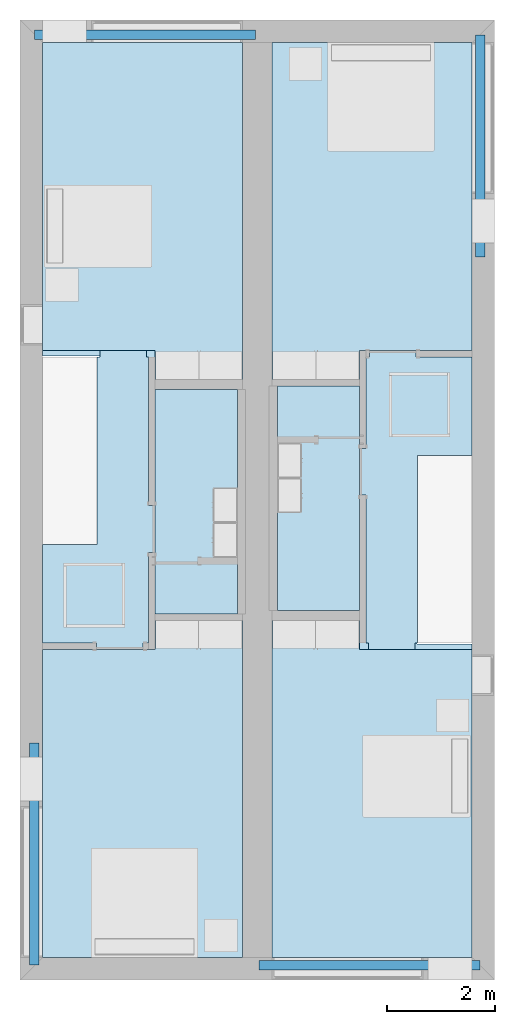
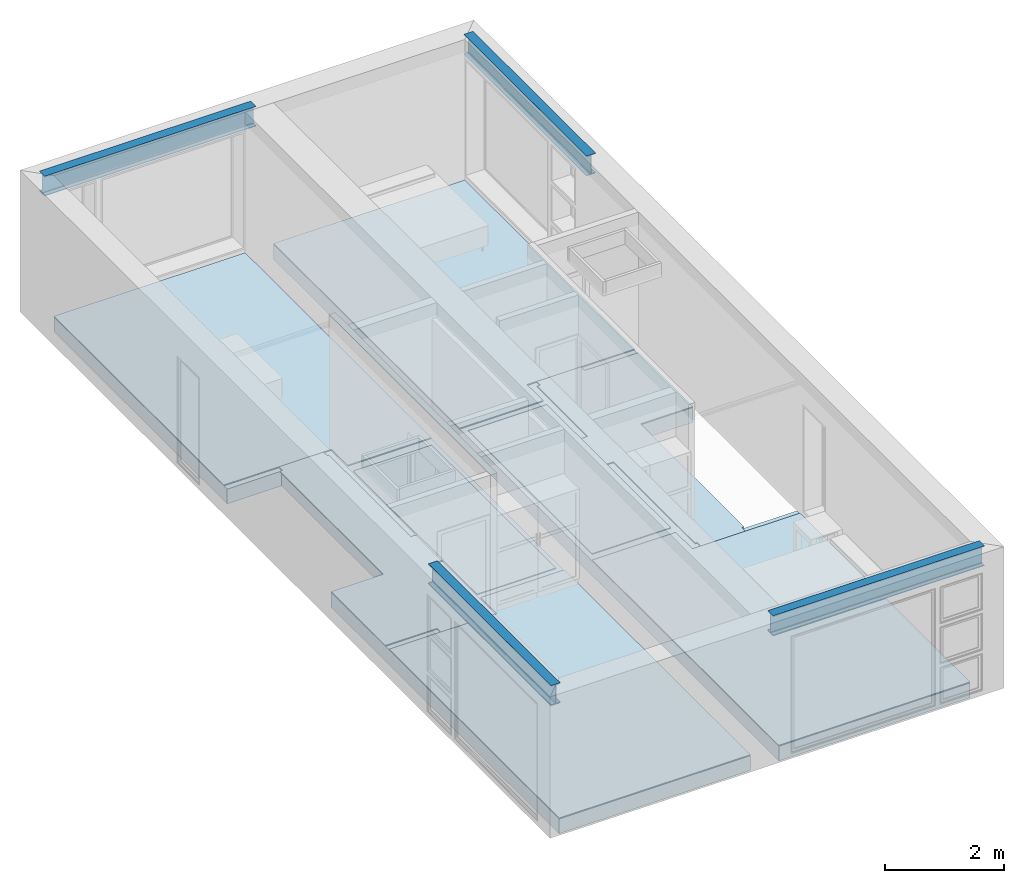
# One storey, part 1 of 12: 10 slabs, 4 beams.
"""IFC2X3 building model written with IfcOpenShell, lengths in metres."""

from ifc_helpers import new_model, entity, si_unit, converted_unit, frame, frame_2d, origin, place, context, project, spatial, polyline, circle_curve, parameter, trimmed, segment, composite_curve, rectangle, outline, extrude, material, layer, layer_set, layer_usage, element, save


model = new_model("IFC2X3")

# Units and contexts
model_context = context("Model", 3, precision=1e-09, world=origin())
plan_context = context("Plan", 3, precision=1e-09, world=origin())
ifc_project = project(units=[si_unit("LENGTHUNIT", "METRE"), si_unit("AREAUNIT", "SQUARE_METRE"), si_unit("VOLUMEUNIT", "CUBIC_METRE"), converted_unit("PLANEANGLEUNIT", "DEGREE", entity("IfcRatioMeasure", 0.0174532925199433), si_unit("PLANEANGLEUNIT", "RADIAN"), dimensions=[0, 0, 0, 0, 0, 0, 0]), si_unit("TIMEUNIT", "SECOND")], contexts=[model_context, plan_context])

# Site, building, storey
site_placement = place(None, origin())
site = spatial("IfcSite", under=ifc_project, at=site_placement, CompositionType="ELEMENT")
building_placement = place(site_placement, origin())
building = spatial("IfcBuilding", under=site, at=building_placement, CompositionType="ELEMENT")
storey_placement = place(building_placement, frame((0.0, 0.0, 3.10000000000038)))
storey = spatial("IfcBuildingStorey", under=building, at=storey_placement, Name="Level 2", CompositionType="ELEMENT", Elevation=3.10000000000038)

# Beams
ifc_material_1 = material(Name="Metal - Steel - 345 MPa")
beam_1_placement = place(storey_placement, frame((0.266612879575049, -13.4017200713696, 2.89999999999983), z_axis=(0.0, 0.0, 1.0), x_axis=(-1.0, 0.0, 0.0)))
element("IfcBeam", 1, at=beam_1_placement, inside=storey, material=ifc_material_1, context=model_context, shape_type="SweptSolid", body=[
    extrude(outline(composite_curve([segment(polyline([(0.190699999999998, -0.0890000000000002), (0.203499999999999, -0.0890000000000002)]), True, "CONTINUOUS"), segment(polyline([(0.203499999999999, -0.0890000000000002), (0.203499999999999, 0.089)]), True, "CONTINUOUS"), segment(polyline([(0.203499999999999, 0.089), (0.190699999999998, 0.089)]), True, "CONTINUOUS"), segment(polyline([(0.190699999999998, 0.089), (0.190699999999998, 0.02105)]), True, "CONTINUOUS"), segment(trimmed(circle_curve(frame_2d((0.173499999999998, 0.0210499999999999), x_axis=(1.0, 0.0)), 0.0172), [parameter(270.0)], [parameter(360.0)], True, "PARAMETER"), False, "CONTINUOUS"), segment(polyline([(0.173499999999998, 0.00384999999999994), (-0.173500000000002, 0.00384999999999994)]), True, "CONTINUOUS"), segment(trimmed(circle_curve(frame_2d((-0.173500000000002, 0.0210499999999999), x_axis=(0.0, -1.0)), 0.0172), [parameter(270.0)], [parameter(360.0)], True, "PARAMETER"), False, "CONTINUOUS"), segment(polyline([(-0.190700000000002, 0.02105), (-0.190700000000002, 0.089)]), True, "CONTINUOUS"), segment(polyline([(-0.190700000000002, 0.089), (-0.203500000000001, 0.089)]), True, "CONTINUOUS"), segment(polyline([(-0.203500000000001, 0.0890000000000001), (-0.203500000000001, -0.0889999999999996)]), True, "CONTINUOUS"), segment(polyline([(-0.203500000000001, -0.0889999999999996), (-0.190700000000002, -0.0889999999999996)]), True, "CONTINUOUS"), segment(polyline([(-0.190700000000002, -0.0889999999999996), (-0.190700000000002, -0.0210500000000001)]), True, "CONTINUOUS"), segment(trimmed(circle_curve(frame_2d((-0.173500000000002, -0.0210500000000002), x_axis=(-1.0, 0.0)), 0.0172), [parameter(270.0)], [parameter(0.0)], True, "PARAMETER"), False, "CONTINUOUS"), segment(polyline([(-0.173500000000002, -0.00385000000000014), (0.173499999999998, -0.00385000000000014)]), True, "CONTINUOUS"), segment(trimmed(circle_curve(frame_2d((0.173499999999998, -0.0210500000000002), x_axis=(0.0, 1.0)), 0.0172), [parameter(270.0)], [parameter(5.08888749034163e-14)], True, "PARAMETER"), False, "CONTINUOUS"), segment(polyline([(0.190699999999998, -0.0210500000000001), (0.190699999999998, -0.0890000000000002)]), True, "CONTINUOUS")], self_intersect=False)), frame((0.0, 4.12127992863035, -0.203500000000007), z_axis=(0.0, -1.0, 0.0), x_axis=(0.0, 0.0, -1.0)), (0.0, 0.0, 1.0), 4.12127992863035),
])
beam_2_placement = place(storey_placement, frame((4.42895432874427, -17.5287668629737, 2.89999999999983), z_axis=(0.0, 0.0, 1.0), x_axis=(0.0, -1.0, 0.0)))
element("IfcBeam", 2, at=beam_2_placement, inside=storey, material=ifc_material_1, context=model_context, shape_type="SweptSolid", body=[
    extrude(outline(composite_curve([segment(polyline([(-0.0890000000000036, -0.1907), (-0.0890000000000036, -0.203500000000001)]), True, "CONTINUOUS"), segment(polyline([(-0.0890000000000036, -0.203500000000001), (0.0889999999999971, -0.203500000000001)]), True, "CONTINUOUS"), segment(polyline([(0.0889999999999971, -0.203500000000001), (0.0889999999999971, -0.1907)]), True, "CONTINUOUS"), segment(polyline([(0.0889999999999971, -0.1907), (0.0210499999999974, -0.1907)]), True, "CONTINUOUS"), segment(trimmed(circle_curve(frame_2d((0.0210499999999974, -0.173500000000001), x_axis=(0.0, -1.0)), 0.0172), [parameter(270.0)], [parameter(360.0)], True, "PARAMETER"), False, "CONTINUOUS"), segment(polyline([(0.00384999999999696, -0.173500000000001), (0.00384999999999696, 0.173499999999999)]), True, "CONTINUOUS"), segment(trimmed(circle_curve(frame_2d((0.0210499999999974, 0.173499999999999), x_axis=(-1.0, 0.0)), 0.0172), [parameter(270.0)], [parameter(360.0)], True, "PARAMETER"), False, "CONTINUOUS"), segment(polyline([(0.0210499999999952, 0.1907), (0.0889999999999971, 0.1907)]), True, "CONTINUOUS"), segment(polyline([(0.0889999999999971, 0.1907), (0.0889999999999971, 0.203499999999999)]), True, "CONTINUOUS"), segment(polyline([(0.0889999999999971, 0.203499999999999), (-0.0890000000000036, 0.203499999999999)]), True, "CONTINUOUS"), segment(polyline([(-0.0890000000000036, 0.203499999999999), (-0.0890000000000036, 0.1907)]), True, "CONTINUOUS"), segment(polyline([(-0.0890000000000036, 0.1907), (-0.0210500000000039, 0.1907)]), True, "CONTINUOUS"), segment(trimmed(circle_curve(frame_2d((-0.0210500000000039, 0.173499999999999), x_axis=(0.0, 1.0)), 0.0172), [parameter(270.0)], [parameter(0.0)], True, "PARAMETER"), False, "CONTINUOUS"), segment(polyline([(-0.00385000000000346, 0.173499999999999), (-0.00385000000000346, -0.173500000000001)]), True, "CONTINUOUS"), segment(trimmed(circle_curve(frame_2d((-0.0210500000000039, -0.173500000000001), x_axis=(1.0, 0.0)), 0.0172), [parameter(270.0)], [parameter(5.08888749034163e-14)], True, "PARAMETER"), False, "CONTINUOUS"), segment(polyline([(-0.0210500000000039, -0.1907), (-0.0890000000000036, -0.1907)]), True, "CONTINUOUS")], self_intersect=False)), frame((0.0, 0.0, -0.203500000000005), z_axis=(0.0, -1.0, 0.0), x_axis=(1.0, 0.0, 0.0)), (0.0, 0.0, -1.0), 4.1),
])
beam_3_placement = place(storey_placement, frame((8.53338712042497, -4.39827992863039, 2.89999999999983)))
element("IfcBeam", 3, at=beam_3_placement, inside=storey, material=ifc_material_1, context=model_context, shape_type="SweptSolid", body=[
    extrude(outline(composite_curve([segment(polyline([(-0.0890000000000003, -0.1907), (-0.0890000000000003, -0.203500000000001)]), True, "CONTINUOUS"), segment(polyline([(-0.0890000000000003, -0.203500000000001), (0.0889999999999993, -0.203500000000001)]), True, "CONTINUOUS"), segment(polyline([(0.0889999999999993, -0.203500000000001), (0.0889999999999993, -0.1907)]), True, "CONTINUOUS"), segment(polyline([(0.0889999999999993, -0.1907), (0.0210499999999996, -0.1907)]), True, "CONTINUOUS"), segment(trimmed(circle_curve(frame_2d((0.0210499999999996, -0.173500000000001), x_axis=(0.0, -1.0)), 0.0172), [parameter(270.0)], [parameter(360.0)], True, "PARAMETER"), False, "CONTINUOUS"), segment(polyline([(0.00384999999999912, -0.173500000000001), (0.00384999999999912, 0.173499999999999)]), True, "CONTINUOUS"), segment(trimmed(circle_curve(frame_2d((0.0210499999999996, 0.173499999999999), x_axis=(-1.0, 0.0)), 0.0172), [parameter(270.0)], [parameter(360.0)], True, "PARAMETER"), False, "CONTINUOUS"), segment(polyline([(0.0210499999999996, 0.1907), (0.0889999999999993, 0.1907)]), True, "CONTINUOUS"), segment(polyline([(0.0889999999999993, 0.1907), (0.0889999999999993, 0.203499999999999)]), True, "CONTINUOUS"), segment(polyline([(0.0889999999999993, 0.203499999999999), (-0.0890000000000003, 0.203499999999999)]), True, "CONTINUOUS"), segment(polyline([(-0.0890000000000003, 0.203499999999999), (-0.0890000000000003, 0.1907)]), True, "CONTINUOUS"), segment(polyline([(-0.0890000000000003, 0.1907), (-0.0210500000000006, 0.1907)]), True, "CONTINUOUS"), segment(trimmed(circle_curve(frame_2d((-0.0210500000000006, 0.173499999999999), x_axis=(0.0, 1.0)), 0.0172), [parameter(270.0)], [parameter(0.0)], True, "PARAMETER"), False, "CONTINUOUS"), segment(polyline([(-0.00385000000000021, 0.173499999999999), (-0.00385000000000021, -0.173500000000001)]), True, "CONTINUOUS"), segment(trimmed(circle_curve(frame_2d((-0.0210500000000006, -0.173500000000001), x_axis=(1.0, 0.0)), 0.0172), [parameter(270.0)], [parameter(5.08888749034163e-14)], True, "PARAMETER"), False, "CONTINUOUS"), segment(polyline([(-0.0210500000000006, -0.1907), (-0.0890000000000003, -0.1907)]), True, "CONTINUOUS")], self_intersect=False)), frame((0.0, 0.0, -0.203500000000005), z_axis=(0.0, -1.0, 0.0), x_axis=(1.0, 0.0, 0.0)), (0.0, 0.0, -1.0), 4.12127992863035),
])
beam_4_placement = place(storey_placement, frame((4.37104567125577, -0.271233137026328, 2.89999999999983), z_axis=(0.0, 0.0, 1.0), x_axis=(0.0, 1.0, 0.0)))
element("IfcBeam", 4, at=beam_4_placement, inside=storey, material=ifc_material_1, context=model_context, shape_type="SweptSolid", body=[
    extrude(outline(composite_curve([segment(polyline([(0.190699999999998, -0.0890000000000001), (0.203499999999999, -0.0890000000000001)]), True, "CONTINUOUS"), segment(polyline([(0.203499999999999, -0.0890000000000001), (0.203499999999999, 0.0890000000000001)]), True, "CONTINUOUS"), segment(polyline([(0.203499999999999, 0.0890000000000001), (0.190699999999998, 0.0890000000000001)]), True, "CONTINUOUS"), segment(polyline([(0.190699999999998, 0.0890000000000001), (0.190699999999998, 0.0210500000000001)]), True, "CONTINUOUS"), segment(trimmed(circle_curve(frame_2d((0.173499999999998, 0.02105), x_axis=(1.0, 0.0)), 0.0172), [parameter(270.0)], [parameter(360.0)], True, "PARAMETER"), False, "CONTINUOUS"), segment(polyline([(0.173499999999998, 0.00385000000000004), (-0.173500000000002, 0.00385000000000004)]), True, "CONTINUOUS"), segment(trimmed(circle_curve(frame_2d((-0.173500000000002, 0.02105), x_axis=(0.0, -1.0)), 0.0172), [parameter(270.0)], [parameter(360.0)], True, "PARAMETER"), False, "CONTINUOUS"), segment(polyline([(-0.190700000000002, 0.0210500000000001), (-0.190700000000002, 0.0890000000000001)]), True, "CONTINUOUS"), segment(polyline([(-0.190700000000002, 0.0890000000000001), (-0.203500000000001, 0.0890000000000001)]), True, "CONTINUOUS"), segment(polyline([(-0.203500000000001, 0.0890000000000002), (-0.203500000000001, -0.0889999999999995)]), True, "CONTINUOUS"), segment(polyline([(-0.203500000000001, -0.0889999999999995), (-0.190700000000002, -0.0889999999999995)]), True, "CONTINUOUS"), segment(polyline([(-0.190700000000002, -0.0889999999999995), (-0.190700000000002, -0.02105)]), True, "CONTINUOUS"), segment(trimmed(circle_curve(frame_2d((-0.173500000000002, -0.0210500000000001), x_axis=(-1.0, 0.0)), 0.0172), [parameter(270.0)], [parameter(0.0)], True, "PARAMETER"), False, "CONTINUOUS"), segment(polyline([(-0.173500000000002, -0.00385000000000004), (0.173499999999998, -0.00385000000000004)]), True, "CONTINUOUS"), segment(trimmed(circle_curve(frame_2d((0.173499999999998, -0.0210500000000001), x_axis=(0.0, 1.0)), 0.0172), [parameter(270.0)], [parameter(5.08888749034163e-14)], True, "PARAMETER"), False, "CONTINUOUS"), segment(polyline([(0.190699999999998, -0.02105), (0.190699999999998, -0.0890000000000001)]), True, "CONTINUOUS")], self_intersect=False)), frame((0.0, 4.1, -0.203500000000007), z_axis=(0.0, -1.0, 0.0), x_axis=(0.0, 0.0, -1.0)), (0.0, 0.0, 1.0), 4.1),
])

# Slabs
ifc_material_2 = material(Name="Wood - Sheathing - plywood")
ifc_layer_1 = layer(ifc_material_2, 0.019)
ifc_material_3 = material(Name="Wood - Dimensional Lumber")
ifc_layer_2 = layer(ifc_material_3, 0.286)
ifc_layer_set_1 = layer_set([ifc_layer_1, ifc_layer_2], Name="Floor:Residential - Wood Joist with")
ifc_layer_usage_1 = layer_usage(ifc_layer_set_1, "AXIS3", "POSITIVE", 0.0)
slab_1_placement = place(storey_placement, frame((0.416999999999999, -17.383, -0.305000000000182)))
element("IfcSlab", 5, at=slab_1_placement, inside=storey, material=ifc_layer_usage_1, Name="Floor:Residential - Wood Joist with", ObjectType="Floor:Residential - Wood Joist with", PredefinedType="FLOOR", context=model_context, shape_type="SweptSolid", body=[
    extrude(outline(polyline([(-1.85400000000001, 8.48299999999998), (-1.85399999999999, -8.48299999999999), (1.85399999999999, -8.48299999999998), (1.85399999999999, -0.825000000000009), (0.799599999999962, -0.825000000000012), (0.799599999999956, 2.66599999999999), (1.85399999999999, 2.66599999999999), (1.85399999999999, 8.48299999999999), (-1.85400000000001, 8.48299999999998)])), frame((1.85399999999999, 8.48299999999999, 0.305), z_axis=(0.0, 0.0, -1.0), x_axis=(-1.0, 0.0, 0.0)), (0.0, 0.0, 1.0), 0.305),
])
ifc_layer_usage_2 = layer_usage(ifc_layer_set_1, "AXIS3", "POSITIVE", 0.0)
slab_2_placement = place(storey_placement, frame((4.675, -17.383, -0.305000000000182)))
element("IfcSlab", 6, at=slab_2_placement, inside=storey, material=ifc_layer_usage_2, Name="Floor:Residential - Wood Joist with", ObjectType="Floor:Residential - Wood Joist with", PredefinedType="FLOOR", context=model_context, shape_type="SweptSolid", body=[
    extrude(outline(polyline([(-1.85400000000001, 8.48299999999998), (-1.854, 0.825000000000003), (-0.829600000000002, 0.825000000000006), (-0.829599999999997, -2.66599999999999), (-1.85399999999999, -2.666), (-1.85399999999999, -8.48299999999999), (1.85399999999999, -8.48299999999998), (1.85399999999999, 8.48299999999999), (-1.85400000000001, 8.48299999999998)])), frame((1.85399999999999, 8.48299999999999, 0.305), z_axis=(0.0, 0.0, -1.0), x_axis=(-1.0, 0.0, 0.0)), (0.0, 0.0, 1.0), 0.305),
])
ifc_material_4 = material(Name="Wood - Flooring")
ifc_layer_3 = layer(ifc_material_4, 0.016)
ifc_material_5 = material(Name="Insulation / Thermal Barriers - Semi-rigid insulation")
ifc_layer_4 = layer(ifc_material_5, 0.003)
ifc_layer_set_2 = layer_set([ifc_layer_3, ifc_layer_4], Name="Floor:Finish Floor - Wood")
ifc_layer_usage_3 = layer_usage(ifc_layer_set_2, "AXIS3", "POSITIVE", 0.0)
slab_3_placement = place(storey_placement, frame((0.416999999999999, -6.66600000000001, 0.0)))
element("IfcSlab", 7, at=slab_3_placement, inside=storey, material=ifc_layer_usage_3, Name="Floor:Finish Floor - Wood", ObjectType="Floor:Finish Floor - Wood", PredefinedType="FLOOR", context=model_context, shape_type="SweptSolid", body=[
    extrude(outline(polyline([(1.85399999999999, 3.1245), (-1.854, 3.12449999999999), (-1.85399999999999, -3.1245), (-0.235000000000004, -3.1245), (-0.235000000000004, -2.5845), (1.854, -2.5845), (1.85399999999999, 3.1245)])), frame((1.854, 3.1245, 0.019), z_axis=(0.0, 0.0, -1.0), x_axis=(-1.0, 0.0, 0.0)), (0.0, 0.0, 1.0), 0.019),
])
ifc_layer_usage_4 = layer_usage(ifc_layer_set_2, "AXIS3", "POSITIVE", 0.0)
slab_4_placement = place(storey_placement, frame((4.675, -6.666, 0.0)))
element("IfcSlab", 8, at=slab_4_placement, inside=storey, material=ifc_layer_usage_4, Name="Floor:Finish Floor - Wood", ObjectType="Floor:Finish Floor - Wood", PredefinedType="FLOOR", context=model_context, shape_type="SweptSolid", body=[
    extrude(outline(polyline([(-1.854, 3.12449999999999), (-1.85399999999999, -2.5845), (0.234999999999979, -2.58449999999999), (0.234999999999979, -3.12449999999999), (1.85399999999999, -3.12449999999999), (1.85399999999999, 3.1245), (-1.854, 3.12449999999999)])), frame((1.85399999999999, 3.12449999999999, 0.019), z_axis=(0.0, 0.0, -1.0), x_axis=(-1.0, 0.0, 0.0)), (0.0, 0.0, 1.0), 0.019),
])
ifc_layer_usage_5 = layer_usage(ifc_layer_set_2, "AXIS3", "POSITIVE", 0.0)
slab_5_placement = place(storey_placement, frame((4.67499999999997, -17.383, 0.0)))
element("IfcSlab", 9, at=slab_5_placement, inside=storey, material=ifc_layer_usage_5, Name="Floor:Finish Floor - Wood", ObjectType="Floor:Finish Floor - Wood", PredefinedType="FLOOR", context=model_context, shape_type="SweptSolid", body=[
    extrude(outline(polyline([(-1.85400000000002, 2.5765), (-1.85399999999999, -3.1325), (1.854, -3.13249999999999), (1.85399999999999, 3.1325), (0.234999999999962, 3.1325), (0.234999999999962, 2.5765), (-1.85400000000002, 2.5765)])), frame((1.854, 3.1325, 0.019), z_axis=(0.0, 0.0, -1.0), x_axis=(-1.0, 0.0, 0.0)), (0.0, 0.0, 1.0), 0.019),
])
ifc_layer_usage_6 = layer_usage(ifc_layer_set_2, "AXIS3", "POSITIVE", 0.0)
slab_6_placement = place(storey_placement, frame((0.416999999999999, -17.383, 0.0)))
element("IfcSlab", 10, at=slab_6_placement, inside=storey, material=ifc_layer_usage_6, Name="Floor:Finish Floor - Wood", ObjectType="Floor:Finish Floor - Wood", PredefinedType="FLOOR", context=model_context, shape_type="SweptSolid", body=[
    extrude(outline(polyline([(-1.85399999999998, -3.1245), (1.85399999999999, -3.12449999999999), (1.85399999999999, 2.58449999999999), (-0.235000000000007, 2.58449999999998), (-0.235000000000007, 3.12449999999999), (-1.85400000000001, 3.12449999999999), (-1.85399999999998, -3.1245)])), frame((1.85399999999999, 3.1245, 0.019), z_axis=(0.0, 0.0, -1.0), x_axis=(-1.0, 0.0, 0.0)), (0.0, 0.0, 1.0), 0.019),
])
ifc_layer_usage_7 = layer_usage(ifc_layer_set_2, "AXIS3", "POSITIVE", 0.0)
slab_7_placement = place(storey_placement, frame((0.416999999999999, -11.674, 0.0)))
element("IfcSlab", 11, at=slab_7_placement, inside=storey, material=ifc_layer_usage_7, Name="Floor:Finish Floor - Wood", ObjectType="Floor:Finish Floor - Wood", PredefinedType="FLOOR", context=model_context, shape_type="SweptSolid", body=[
    extrude(outline(polyline([(-0.920500000000001, -0.106051178510584), (-1.0445, -0.106051178510584), (-1.0445, -0.970051178510583), (-0.920500000000001, -0.970051178510583), (-0.920500000000001, -2.65), (-0.820499999999994, -2.65), (-0.820499999999993, -2.774), (0.0435000000000064, -2.774), (0.0435000000000061, -2.65), (1.0445, -2.64999999999999), (1.0445, -0.825), (0.0300999999999994, -0.825000000000002), (0.0300999999999913, 2.65), (-0.0217999999999956, 2.65), (-0.0217999999999961, 2.774), (-0.885799999999996, 2.774), (-0.885799999999996, 2.65), (-0.920500000000001, 2.65), (-0.920500000000001, -0.106051178510584)])), frame((1.0445, 2.774, 0.019), z_axis=(0.0, 0.0, -1.0), x_axis=(-1.0, 0.0, 0.0)), (0.0, 0.0, 1.0), 0.019),
])
ifc_layer_usage_8 = layer_usage(ifc_layer_set_2, "AXIS3", "POSITIVE", 0.0)
slab_8_placement = place(storey_placement, frame((6.29400000000001, -11.674, 0.0)))
element("IfcSlab", 12, at=slab_8_placement, inside=storey, material=ifc_layer_usage_8, Name="Floor:Finish Floor - Wood", ObjectType="Floor:Finish Floor - Wood", PredefinedType="FLOOR", context=model_context, shape_type="SweptSolid", body=[
    extrude(outline(polyline([(0.920500000000015, 0.0906157649284805), (1.04449999999997, 0.0906157649284816), (1.04449999999997, 0.95461576492848), (0.920499999999994, 0.95461576492848), (0.920499999999989, 2.65), (0.860499999999979, 2.65), (0.860499999999979, 2.774), (-0.00350000000002086, 2.774), (-0.00350000000002086, 2.65), (-1.04449999999999, 2.64999999999999), (-1.04449999999999, 0.824999999999998), (-0.0301000000000018, 0.825000000000003), (-0.0300999999999823, -2.65), (0.0172000000000015, -2.65), (0.0172000000000026, -2.774), (0.881200000000003, -2.77399999999999), (0.881200000000002, -2.64999999999999), (0.920500000000024, -2.64999999999999), (0.920500000000015, 0.0906157649284805)])), frame((1.04449999999997, 2.774, 0.019), z_axis=(0.0, 0.0, -1.0), x_axis=(-1.0, 0.0, 0.0)), (0.0, 0.0, 1.0), 0.019),
])
ifc_material_6 = material(Name="Ceramic Tile")
ifc_layer_5 = layer(ifc_material_6, 0.01)
ifc_material_7 = material(Name="Masonry - Grout")
ifc_layer_6 = layer(ifc_material_7, 0.003)
ifc_layer_set_3 = layer_set([ifc_layer_5, ifc_layer_6], Name="Floor:Finish Floor - Ceramic Tile")
ifc_layer_usage_9 = layer_usage(ifc_layer_set_3, "AXIS3", "POSITIVE", 0.0)
slab_9_placement = place(storey_placement, frame((2.50599999999999, -11.01, 0.0)))
element("IfcSlab", 13, at=slab_9_placement, inside=storey, material=ifc_layer_usage_9, Name="Floor:Finish Floor - Ceramic Tile", ObjectType="Floor:Finish Floor - Ceramic Tile", PredefinedType="FLOOR", context=model_context, shape_type="SweptSolid", body=[
    extrude(rectangle(XDim=4.16, YDim=1.52399999999999, at=frame_2d((0.0, 0.0), x_axis=(0.0, -1.0))), frame((0.761999999999997, 2.08, 0.0129999999999997), z_axis=(0.0, 0.0, -1.0), x_axis=(-1.0, 0.0, 0.0)), (0.0, 0.0, 1.0), 0.0129999999999997),
])
ifc_layer_usage_10 = layer_usage(ifc_layer_set_3, "AXIS3", "POSITIVE", 0.0)
slab_10_placement = place(storey_placement, frame((4.76999999999999, -10.95, 0.0)))
element("IfcSlab", 14, at=slab_10_placement, inside=storey, material=ifc_layer_usage_10, Name="Floor:Finish Floor - Ceramic Tile", ObjectType="Floor:Finish Floor - Ceramic Tile", PredefinedType="FLOOR", context=model_context, shape_type="SweptSolid", body=[
    extrude(rectangle(XDim=4.16000000000001, YDim=1.52400000000001, at=frame_2d((0.0, 0.0), x_axis=(0.0, -1.0))), frame((0.762000000000007, 2.08, 0.0129999999999997), z_axis=(0.0, 0.0, -1.0), x_axis=(-1.0, 0.0, 0.0)), (0.0, 0.0, 1.0), 0.0129999999999997),
])

save(model, "model.ifc")
